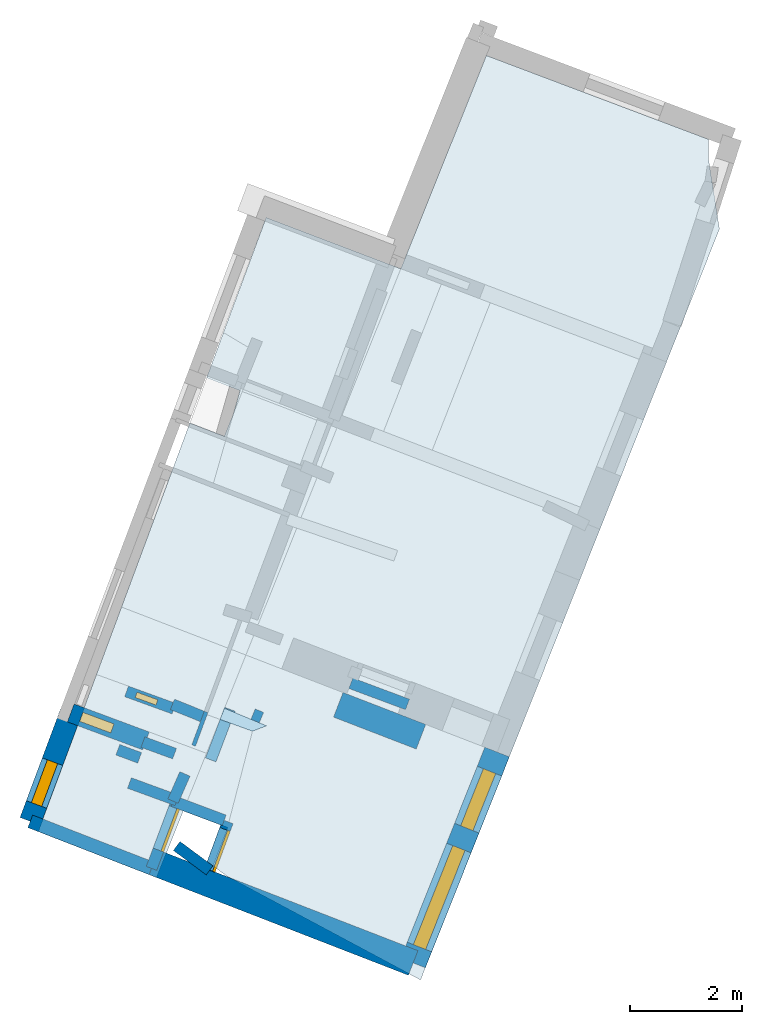
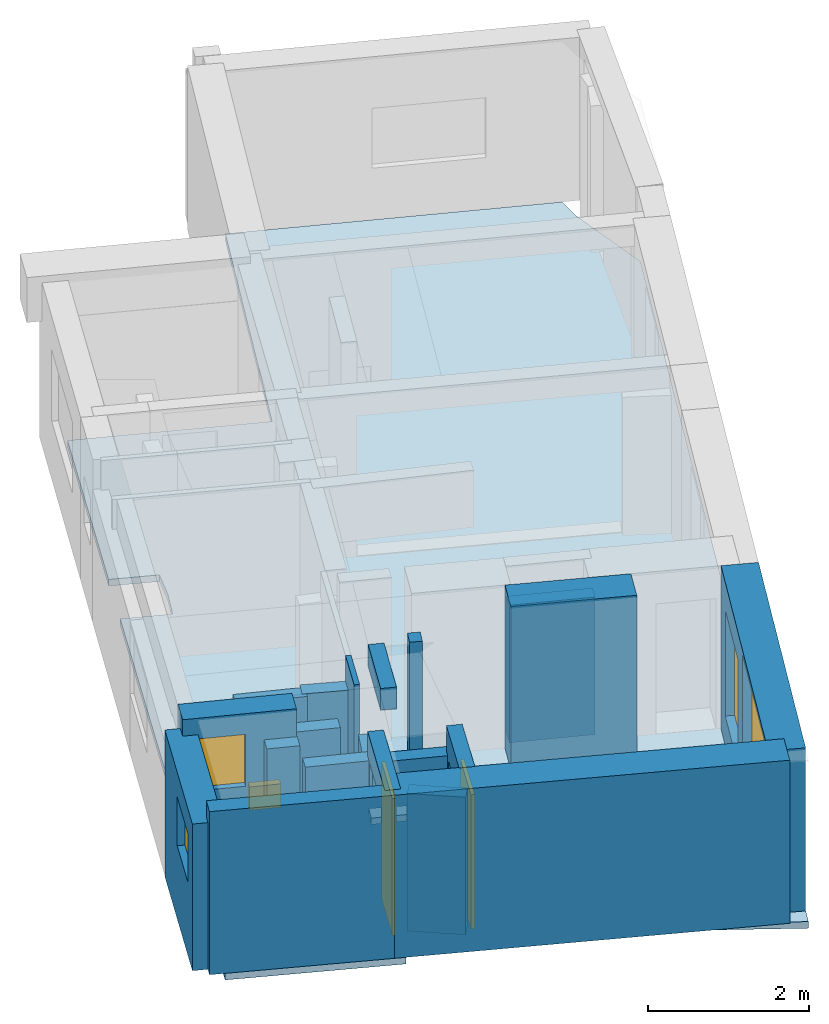
# One storey, part 1 of 5: 20 walls, 5 windows, 2 doors, 2 slabs, 7 openings.
"""IFC2X3 building model written with IfcOpenShell, lengths in metres."""

from ifc_helpers import new_model, entity, si_unit, converted_unit, derived_unit, direction, frame, frame_2d, origin, origin_2d_with_axis, place, context, subcontext, project, spatial, polyline, rectangle, outline, extrude, source, transform, mapped, material, layer, layer_set, layer_usage, type_object, type_shapes, element, fill, save


model = new_model("IFC2X3")

# Units and contexts
model_context = context("Model", 3, precision=1e-05, world=origin(), true_north=direction((0.0, 1.0)))
body_context = subcontext(model_context, "Body", "Model", "MODEL_VIEW")
ifc_project = project(units=[si_unit("LENGTHUNIT", "METRE"), si_unit("AREAUNIT", "SQUARE_METRE"), si_unit("VOLUMEUNIT", "CUBIC_METRE"), converted_unit("PLANEANGLEUNIT", "DEGREE", entity("IfcRatioMeasure", 0.0174532925199433), si_unit("PLANEANGLEUNIT", "RADIAN"), dimensions=[0, 0, 0, 0, 0, 0, 0]), si_unit("MASSUNIT", "GRAM", prefix="KILO"), derived_unit("MASSDENSITYUNIT", [(si_unit("MASSUNIT", "GRAM", prefix="KILO"), 1), (si_unit("LENGTHUNIT", "METRE"), -3)]), derived_unit("MOMENTOFINERTIAUNIT", [(si_unit("LENGTHUNIT", "METRE"), 4)]), si_unit("TIMEUNIT", "SECOND"), si_unit("FREQUENCYUNIT", "HERTZ"), si_unit("THERMODYNAMICTEMPERATUREUNIT", "DEGREE_CELSIUS"), derived_unit("THERMALTRANSMITTANCEUNIT", [(si_unit("MASSUNIT", "GRAM", prefix="KILO"), 1), (si_unit("THERMODYNAMICTEMPERATUREUNIT", "KELVIN"), -1), (si_unit("TIMEUNIT", "SECOND"), -3)]), derived_unit("VOLUMETRICFLOWRATEUNIT", [(si_unit("LENGTHUNIT", "METRE"), 3), (si_unit("TIMEUNIT", "SECOND"), -1)]), si_unit("ELECTRICCURRENTUNIT", "AMPERE"), si_unit("ELECTRICVOLTAGEUNIT", "VOLT"), si_unit("POWERUNIT", "WATT"), si_unit("FORCEUNIT", "NEWTON", prefix="KILO"), si_unit("ILLUMINANCEUNIT", "LUX"), si_unit("LUMINOUSFLUXUNIT", "LUMEN"), si_unit("LUMINOUSINTENSITYUNIT", "CANDELA"), derived_unit("USERDEFINED", [(si_unit("MASSUNIT", "GRAM", prefix="KILO"), -1), (si_unit("LENGTHUNIT", "METRE"), -2), (si_unit("TIMEUNIT", "SECOND"), 3), (si_unit("LUMINOUSFLUXUNIT", "LUMEN"), 1)]), derived_unit("LINEARVELOCITYUNIT", [(si_unit("LENGTHUNIT", "METRE"), 1), (si_unit("TIMEUNIT", "SECOND"), -1)]), si_unit("PRESSUREUNIT", "PASCAL"), derived_unit("USERDEFINED", [(si_unit("LENGTHUNIT", "METRE"), -2), (si_unit("MASSUNIT", "GRAM", prefix="KILO"), 1), (si_unit("TIMEUNIT", "SECOND"), -2)]), derived_unit("LINEARFORCEUNIT", [(si_unit("MASSUNIT", "GRAM", prefix="KILO"), 1), (si_unit("LENGTHUNIT", "METRE"), 1), (si_unit("TIMEUNIT", "SECOND"), -2), (si_unit("LENGTHUNIT", "METRE"), -1)]), derived_unit("PLANARFORCEUNIT", [(si_unit("MASSUNIT", "GRAM", prefix="KILO"), 1), (si_unit("LENGTHUNIT", "METRE"), 1), (si_unit("TIMEUNIT", "SECOND"), -2), (si_unit("LENGTHUNIT", "METRE"), -2)])], contexts=[model_context])

# Site, building, storey
placement_1 = place(None, origin())
site = spatial("IfcSite", under=ifc_project, at=placement_1, CompositionType="ELEMENT")
building = spatial("IfcBuilding", under=site, at=placement_1, CompositionType="ELEMENT")
storey_placement = place(placement_1, frame((0.0, 0.0, -81.7791442871094)))
storey = spatial("IfcBuildingStorey", under=building, at=storey_placement, Name="Level 1", CompositionType="ELEMENT", Elevation=-81.7791442871094)

# Slabs
ifc_material_1 = material(Name="Floor default")
ifc_layer_1 = layer(ifc_material_1, 0.1)
ifc_layer_set_1 = layer_set([ifc_layer_1], Name="Floor : 100mm")
ifc_layer_usage_1 = layer_usage(ifc_layer_set_1, "AXIS3", "POSITIVE", 0.0)
slab_type_1 = type_object("IfcSlabType", Name="Floor : 100mm", PredefinedType="FLOOR")
slab_1_placement = place(storey_placement, origin())
element("IfcSlab", 1, at=slab_1_placement, inside=storey, type_object=slab_type_1, material=ifc_layer_usage_1, Name="Floor : 100mm", ObjectType="Floor : 100mm", PredefinedType="FLOOR", context=body_context, shape_type="SweptSolid", body=[
    extrude(outline(polyline([(-3.49388003349304, 1.42888998985291), (-4.0716700553894, 1.63903999328613), (-3.99167990684509, 1.83849000930786), (-3.24238991737366, 1.52546000480652), (-3.49388003349304, 1.42888998985291)])), frame((0.0, 0.0, -0.1), z_axis=(0.0, 0.0, 1.0), x_axis=(1.0, 0.0, 0.0)), (0.0, 0.0, 1.0), 0.1),
])
ifc_layer_2 = layer(ifc_material_1, 0.1)
ifc_layer_set_2 = layer_set([ifc_layer_2], Name="Floor : 100mm")
ifc_layer_usage_2 = layer_usage(ifc_layer_set_2, "AXIS3", "POSITIVE", 0.0)
slab_type_2 = type_object("IfcSlabType", Name="Floor : 100mm", PredefinedType="FLOOR")
slab_2_placement = place(storey_placement, origin())
element("IfcSlab", 2, at=slab_2_placement, inside=storey, type_object=slab_type_2, material=ifc_layer_usage_2, Name="Floor : 100mm", ObjectType="Floor : 100mm", PredefinedType="FLOOR", context=body_context, shape_type="SweptSolid", body=[
    extrude(outline(polyline([(-0.497680008411407, -3.00534009933472), (1.08619999885559, 0.973829984664917), (2.70121002197266, 5.03125), (3.83908009529114, 7.88992023468018), (4.83017015457153, 10.3798503875732), (4.63234996795654, 11.6451902389526), (4.63234996795654, 11.9805402755737), (0.67492002248764, 13.4735298156738), (-0.849510014057159, 9.67273044586182), (-3.2506799697876, 10.5857696533203), (-4.01208019256592, 8.53514003753662), (-4.31142997741699, 7.72891998291016), (-3.71643996238708, 7.50004005432129), (-3.83523011207581, 7.08568000793457), (-3.99607992172241, 6.68628978729248), (-4.61093997955322, 6.92226982116699), (-4.93342018127441, 6.05374002456665), (-5.82860994338989, 3.64277005195618), (-6.27504014968872, 2.44042992591858), (-6.49514007568359, 1.84764003753662), (-7.31494998931885, -0.360320001840591), (-5.2023401260376, -1.17999005317688), (-4.90777015686035, -0.44556999206543), (-4.7262601852417, 0.00698000006377697), (-3.94035005569458, -0.28753998875618), (-4.20233011245728, -0.968050003051758), (-3.93070006370544, -1.16923999786377), (-0.497680008411407, -3.00534009933472)])), frame((0.0, 0.0, -0.1), z_axis=(0.0, 0.0, 1.0), x_axis=(1.0, 0.0, 0.0)), (0.0, 0.0, 1.0), 0.1),
])

# Walls
ifc_material_2 = material(Name="Default wall")
ifc_layer_3 = layer(ifc_material_2, 0.2)
ifc_layer_set_3 = layer_set([ifc_layer_3], Name="wall_thickness_0.2000")
ifc_layer_usage_3 = layer_usage(ifc_layer_set_3, "AXIS2", "POSITIVE", -0.1)
wall_type_1 = type_object("IfcWallType", Name="wall_thickness_0.2000", PredefinedType="STANDARD", material=ifc_layer_set_3)
wall_1_placement = place(storey_placement, frame((-4.69764743649111, 0.668284849217164, 0.0), z_axis=(0.0, 0.0, 1.0), x_axis=(-0.401525160425037, -0.915847992597924, 0.0)))
element("IfcWallStandardCase", 3, at=wall_1_placement, inside=storey, type_object=wall_type_1, material=ifc_layer_usage_3, Name="Wall:9", ObjectType="Wall", context=body_context, shape_type="SweptSolid", body=[
    extrude(outline(polyline([(0.530077874070879, -0.1), (0.530077874070879, 0.1), (0.0, 0.1), (0.0, -0.1), (0.530077874070879, -0.1)])), origin(), (0.0, 0.0, 1.0), 2.08080291748047),
])
wall_2_placement = place(storey_placement, frame((-4.84477685605442, -0.616664605192103, 0.0), z_axis=(0.0, 0.0, 1.0), x_axis=(0.803591772922501, -0.595180865360499, 0.0)))
element("IfcWallStandardCase", 4, at=wall_2_placement, inside=storey, type_object=wall_type_1, material=ifc_layer_usage_3, Name="Wall:11", ObjectType="Wall", context=body_context, shape_type="SweptSolid", body=[
    extrude(outline(polyline([(0.729999710162035, -0.1), (0.729999710162035, 0.1), (0.0, 0.1), (0.0, -0.1), (0.729999710162035, -0.1)])), origin(), (0.0, 0.0, 1.0), 2.08080291748047),
])
wall_3_placement = place(storey_placement, frame((-5.68688132326046, 0.505307002474708, 0.0), z_axis=(0.0, 0.0, 1.0), x_axis=(0.939382169316775, -0.34287190023347, 0.0)))
element("IfcWallStandardCase", 5, at=wall_3_placement, inside=storey, type_object=wall_type_1, material=ifc_layer_usage_3, Name="Wall:34", ObjectType="Wall", context=body_context, shape_type="SweptSolid", body=[
    extrude(outline(polyline([(0.902038816711558, -0.1), (0.902038816711558, 0.1), (0.0, 0.1), (0.0, -0.1), (0.902038816711558, -0.1)])), origin(), (0.0, 0.0, 1.0), 2.09180450439453),
])
wall_4_placement = place(storey_placement, frame((-5.50497072982383, 0.953843812868215, 0.0), z_axis=(0.0, 0.0, 1.0), x_axis=(-0.936839946646351, 0.34975836568646, 0.0)))
element("IfcWallStandardCase", 6, at=wall_4_placement, inside=storey, type_object=wall_type_1, material=ifc_layer_usage_3, Name="Wall:36", ObjectType="Wall", context=body_context, shape_type="SweptSolid", body=[
    extrude(outline(polyline([(0.415000130487096, -0.1), (0.415000130487096, 0.1), (0.0, 0.1), (0.0, -0.1), (0.415000130487096, -0.1)])), origin(), (0.0, 0.0, 1.0), 2.08080291748047),
])
wall_5_placement = place(storey_placement, frame((-4.91048679587615, 0.18281424211578, 0.0), z_axis=(0.0, 0.0, 1.0), x_axis=(0.936404472151035, -0.35092259051754, 0.0)))
element("IfcWallStandardCase", 7, at=wall_5_placement, inside=storey, type_object=wall_type_1, material=ifc_layer_usage_3, Name="Wall:40", ObjectType="Wall", context=body_context, shape_type="SweptSolid", body=[
    extrude(outline(polyline([(0.974388960445518, -0.1), (0.974388960445518, 0.1), (0.0, 0.1), (0.0, -0.1), (0.974388960445518, -0.1)])), origin(), (0.0, 0.0, 1.0), 2.08080291748047),
])

# Wall, opening, window
wall_6_placement = place(storey_placement, frame((-5.73748285038523, 2.13850509301801, 0.0), z_axis=(0.0, 0.0, 1.0), x_axis=(0.939770987295622, -0.341804756311861, 0.0)))
wall_6 = element("IfcWallStandardCase", 8, at=wall_6_placement, inside=storey, type_object=wall_type_1, material=ifc_layer_usage_3, Name="Wall:45", ObjectType="Wall", context=body_context, shape_type="SweptSolid", body=[
    extrude(outline(polyline([(0.899999824950968, -0.1), (0.899999824950968, 0.1), (0.0, 0.1), (0.0, -0.1), (0.899999824950968, -0.1)])), origin(), (0.0, 0.0, 1.0), 2.08080291748047),
])
opening_1_placement = place(wall_6_placement, frame((0.179999695044436, -0.1, 0.408058166503906)))
opening_1 = element("IfcOpeningElement", 9, at=opening_1_placement, cuts=wall_6, Name="Opening : 395 x 355 : 11", ObjectType="Opening", context=body_context, shape_type="SweptSolid", body=[
    extrude(rectangle(XDim=0.395, YDim=0.355, at=frame_2d((0.1775, 0.1975), x_axis=(0.0, 1.0))), frame((0.0, 0.0, 0.0), z_axis=(0.0, 1.0, 0.0), x_axis=(0.0, 0.0, 1.0)), (0.0, 0.0, 1.0), 0.2),
])
ifc_material_3 = material(Name="Window Default")
window_style_1 = type_object("IfcWindowStyle", Name="Window : 395 x 355mm", ConstructionType="NOTDEFINED", OperationType="NOTDEFINED", ParameterTakesPrecedence=False, Sizeable=False, material=ifc_material_3)
shared_shape_1 = source(origin(), body_context, "Body", "SweptSolid", [
    extrude(rectangle(XDim=0.1, YDim=0.395, at=origin_2d_with_axis()), frame((0.1975, 0.1, 0.0), z_axis=(0.0, 0.0, 1.0), x_axis=(0.0, 1.0, 0.0)), (0.0, 0.0, 1.0), 0.355),
])
type_shapes(window_style_1, [shared_shape_1])
window_1_placement = place(opening_1_placement, origin())
window_1 = element("IfcWindow", 10, at=window_1_placement, inside=storey, type_object=window_style_1, Name="Window : 395 x 355mm : 9", ObjectType="Window : 395 x 355mm", OverallHeight=0.355, OverallWidth=0.395, context=body_context, shape_type="MappedRepresentation", body=[
    mapped(shared_shape_1, transform((0.0, 0.0, 0.0), scale=1.0)),
])
fill(opening_1, window_1)

# Wall, opening, door
wall_7_placement = place(storey_placement, frame((-4.83952210720287, 0.196022988020994, 0.0), z_axis=(0.0, 0.0, 1.0), x_axis=(-0.351109422703941, -0.93633443453101, 0.0)))
wall_7 = element("IfcWallStandardCase", 11, at=wall_7_placement, inside=storey, type_object=wall_type_1, material=ifc_layer_usage_3, Name="Wall:61", ObjectType="Wall", context=body_context, shape_type="SweptSolid", body=[
    extrude(outline(polyline([(1.29416324547579, -0.1), (1.29416324547579, 0.1), (0.0, 0.1), (0.0, -0.1), (1.29416324547579, -0.1)])), origin(), (0.0, 0.0, 1.0), 2.46645965576172),
])
opening_2_placement = place(wall_7_placement, frame((0.135700394585531, -0.1, 0.0158004760742188)))
opening_2 = element("IfcOpeningElement", 12, at=opening_2_placement, cuts=wall_7, Name="Opening : 810 x 2070 : 16", ObjectType="Opening", context=body_context, shape_type="SweptSolid", body=[
    extrude(rectangle(XDim=0.81, YDim=2.07, at=frame_2d((1.035, 0.405), x_axis=(0.0, 1.0))), frame((0.0, 0.0, 0.0), z_axis=(0.0, 1.0, 0.0), x_axis=(0.0, 0.0, 1.0)), (0.0, 0.0, 1.0), 0.2),
])
ifc_material_4 = material(Name="Door Panel")
door_style_1 = type_object("IfcDoorStyle", Name="Door : 810 x 2070mm", ConstructionType="NOTDEFINED", OperationType="SINGLE_SWING_RIGHT", ParameterTakesPrecedence=False, Sizeable=False, material=ifc_material_4)
shared_shape_2 = source(origin(), body_context, "Body", "SweptSolid", [
    extrude(rectangle(XDim=0.05, YDim=0.81, at=origin_2d_with_axis()), frame((0.405, 0.175, 0.0), z_axis=(0.0, 0.0, 1.0), x_axis=(0.0, 1.0, 0.0)), (0.0, 0.0, 1.0), 2.07),
])
type_shapes(door_style_1, [shared_shape_2])
door_1_placement = place(opening_2_placement, origin())
door_1 = element("IfcDoor", 13, at=door_1_placement, inside=storey, type_object=door_style_1, Name="Door : 810 x 2070mm : 2", ObjectType="Door : 810 x 2070mm", OverallHeight=2.07, OverallWidth=0.81, context=body_context, shape_type="MappedRepresentation", body=[
    mapped(shared_shape_2, transform((0.0, 0.0, 0.0), scale=1.0)),
])
fill(opening_2, door_1)

wall_8_placement = place(storey_placement, frame((-3.93370529681326, -0.183239726440564, 0.0), z_axis=(0.0, 0.0, 1.0), x_axis=(-0.345762204330425, -0.938322171781401, 0.0)))
wall_8 = element("IfcWallStandardCase", 14, at=wall_8_placement, inside=storey, type_object=wall_type_1, material=ifc_layer_usage_3, Name="Wall:76", ObjectType="Wall", context=body_context, shape_type="SweptSolid", body=[
    extrude(outline(polyline([(0.927830297948159, -0.1), (0.927830297948159, 0.1), (0.0, 0.1), (0.0, -0.1), (0.927830297948159, -0.1)])), origin(), (0.0, 0.0, 1.0), 2.46645965576172),
])
opening_3_placement = place(wall_8_placement, frame((0.146446355377596, -0.1, 0.00879669189453125)))
opening_3 = element("IfcOpeningElement", 15, at=opening_3_placement, cuts=wall_8, Name="Opening : 775 x 2030 : 22", ObjectType="Opening", context=body_context, shape_type="SweptSolid", body=[
    extrude(rectangle(XDim=0.775, YDim=2.03, at=frame_2d((1.015, 0.3875), x_axis=(0.0, 1.0))), frame((0.0, 0.0, 0.0), z_axis=(0.0, 1.0, 0.0), x_axis=(0.0, 0.0, 1.0)), (0.0, 0.0, 1.0), 0.2),
])
door_style_2 = type_object("IfcDoorStyle", Name="Door : 775 x 2030mm", ConstructionType="NOTDEFINED", OperationType="SINGLE_SWING_RIGHT", ParameterTakesPrecedence=False, Sizeable=False, material=ifc_material_4)
shared_shape_3 = source(origin(), body_context, "Body", "SweptSolid", [
    extrude(rectangle(XDim=0.05, YDim=0.775, at=origin_2d_with_axis()), frame((0.3875, 0.175, 0.0), z_axis=(0.0, 0.0, 1.0), x_axis=(0.0, 1.0, 0.0)), (0.0, 0.0, 1.0), 2.03),
])
type_shapes(door_style_2, [shared_shape_3])
door_2_placement = place(opening_3_placement, origin())
door_2 = element("IfcDoor", 16, at=door_2_placement, inside=storey, type_object=door_style_2, Name="Door : 775 x 2030mm : 5", ObjectType="Door : 775 x 2030mm", OverallHeight=2.03, OverallWidth=0.775, context=body_context, shape_type="MappedRepresentation", body=[
    mapped(shared_shape_3, transform((0.0, 0.0, 0.0), scale=1.0)),
])
fill(opening_3, door_2)

# Walls
wall_9_placement = place(storey_placement, frame((-1.74015555347934, 2.28371564240451, 0.0), z_axis=(0.0, 0.0, 1.0), x_axis=(0.936778285254974, -0.349923483457099, 0.0)))
element("IfcWallStandardCase", 17, at=wall_9_placement, inside=storey, type_object=wall_type_1, material=ifc_layer_usage_3, Name="Wall:80", ObjectType="Wall", context=body_context, shape_type="SweptSolid", body=[
    extrude(outline(polyline([(1.07814449094911, -0.1), (1.07814449094911, 0.1), (0.0, 0.1), (0.0, -0.1), (1.07814449094911, -0.1)])), origin(), (0.0, 0.0, 1.0), 2.08080291748047),
])
wall_10_placement = place(storey_placement, frame((-4.92037903602146, 1.90727218548898, 0.0), z_axis=(0.0, 0.0, 1.0), x_axis=(0.927278241760795, -0.374372892123626, 0.0)))
element("IfcWallStandardCase", 18, at=wall_10_placement, inside=storey, type_object=wall_type_1, material=ifc_layer_usage_3, Name="Wall:86", ObjectType="Wall", context=body_context, shape_type="SweptSolid", body=[
    extrude(outline(polyline([(0.609526141531859, -0.1), (0.609526141531859, 0.1), (0.0, 0.1), (0.0, -0.1), (0.609526141531859, -0.1)])), origin(), (0.0, 0.0, 1.0), 2.08080291748047),
])
ifc_layer_4 = layer(ifc_material_2, 0.469999998807907)
ifc_layer_set_4 = layer_set([ifc_layer_4], Name="wall_thickness_0.4700")
ifc_layer_usage_4 = layer_usage(ifc_layer_set_4, "AXIS2", "POSITIVE", -0.234999999403954)
wall_type_2 = type_object("IfcWallType", Name="wall_thickness_0.4700", PredefinedType="STANDARD", material=ifc_layer_set_4)
wall_11_placement = place(storey_placement, frame((-1.96446391737697, 1.89940987600021, 0.0), z_axis=(0.0, 0.0, 1.0), x_axis=(0.932920275492901, -0.360082989842966, 0.0)))
element("IfcWallStandardCase", 19, at=wall_11_placement, inside=storey, type_object=wall_type_2, material=ifc_layer_usage_4, Name="Wall:14", ObjectType="Wall", context=body_context, shape_type="SweptSolid", body=[
    extrude(outline(polyline([(1.57982514113174, -0.234999999403954), (1.57982514113174, 0.234999999403954), (0.0, 0.234999999403954), (0.0, -0.234999999403954), (1.57982514113174, -0.234999999403954)])), origin(), (0.0, 0.0, 1.0), 2.46645965576172),
])

# Wall, openings, windows
wall_12_placement = place(storey_placement, frame((0.866960459031093, 1.05848709394959, 0.0), z_axis=(0.0, 0.0, 1.0), x_axis=(-0.369820361237659, -0.929103277582233, 0.0)))
wall_12 = element("IfcWallStandardCase", 20, at=wall_12_placement, inside=storey, type_object=wall_type_2, material=ifc_layer_usage_4, Name="Wall:24", ObjectType="Wall", context=body_context, shape_type="SweptSolid", body=[
    extrude(outline(polyline([(4.04742735328638, -0.234999999403954), (4.04742735328638, 0.234999999403954), (0.0, 0.234999999403954), (0.0, -0.234999999403954), (4.04742735328638, -0.234999999403954)])), origin(), (0.0, 0.0, 1.0), 2.46645965576172),
])
opening_4_placement = place(wall_12_placement, frame((1.84168409532844, -0.234999999403954, 0.450057983398438)))
opening_4 = element("IfcOpeningElement", 21, at=opening_4_placement, cuts=wall_12, Name="Opening : 1900 x 1950 : 7", ObjectType="Opening", context=body_context, shape_type="SweptSolid", body=[
    extrude(rectangle(XDim=1.9, YDim=1.95, at=frame_2d((0.975, 0.95), x_axis=(0.0, 1.0))), frame((0.0, 0.0, 0.0), z_axis=(0.0, 1.0, 0.0), x_axis=(0.0, 0.0, 1.0)), (0.0, 0.0, 1.0), 0.469999998807907),
])
opening_5_placement = place(wall_12_placement, frame((0.366683535874474, -0.234999999403954, 0.445060729980469)))
opening_5 = element("IfcOpeningElement", 22, at=opening_5_placement, cuts=wall_12, Name="Opening : 1095 x 1605 : 8", ObjectType="Opening", context=body_context, shape_type="SweptSolid", body=[
    extrude(rectangle(XDim=1.095, YDim=1.605, at=frame_2d((0.8025, 0.5475), x_axis=(0.0, 1.0))), frame((0.0, 0.0, 0.0), z_axis=(0.0, 1.0, 0.0), x_axis=(0.0, 0.0, 1.0)), (0.0, 0.0, 1.0), 0.469999998807907),
])
window_style_2 = type_object("IfcWindowStyle", Name="Window : 1900 x 1950mm", ConstructionType="NOTDEFINED", OperationType="NOTDEFINED", ParameterTakesPrecedence=False, Sizeable=False, material=ifc_material_3)
shared_shape_4 = source(origin(), body_context, "Body", "SweptSolid", [
    extrude(rectangle(XDim=0.234999999403954, YDim=1.9, at=origin_2d_with_axis()), frame((0.95, 0.234999999403954, 0.0), z_axis=(0.0, 0.0, 1.0), x_axis=(0.0, 1.0, 0.0)), (0.0, 0.0, 1.0), 1.95),
])
type_shapes(window_style_2, [shared_shape_4])
window_2_placement = place(opening_4_placement, origin())
window_2 = element("IfcWindow", 23, at=window_2_placement, inside=storey, type_object=window_style_2, Name="Window : 1900 x 1950mm : 6", ObjectType="Window : 1900 x 1950mm", OverallHeight=1.95, OverallWidth=1.9, context=body_context, shape_type="MappedRepresentation", body=[
    mapped(shared_shape_4, transform((0.0, 0.0, 0.0), scale=1.0)),
])
fill(opening_4, window_2)
window_style_3 = type_object("IfcWindowStyle", Name="Window : 1095 x 1605mm", ConstructionType="NOTDEFINED", OperationType="NOTDEFINED", ParameterTakesPrecedence=False, Sizeable=False, material=ifc_material_3)
shared_shape_5 = source(origin(), body_context, "Body", "SweptSolid", [
    extrude(rectangle(XDim=0.234999999403954, YDim=1.095, at=origin_2d_with_axis()), frame((0.5475, 0.234999999403954, 0.0), z_axis=(0.0, 0.0, 1.0), x_axis=(0.0, 1.0, 0.0)), (0.0, 0.0, 1.0), 1.605),
])
type_shapes(window_style_3, [shared_shape_5])
window_3_placement = place(opening_5_placement, origin())
window_3 = element("IfcWindow", 24, at=window_3_placement, inside=storey, type_object=window_style_3, Name="Window : 1095 x 1605mm : 7", ObjectType="Window : 1095 x 1605mm", OverallHeight=1.605, OverallWidth=1.095, context=body_context, shape_type="MappedRepresentation", body=[
    mapped(shared_shape_5, transform((0.0, 0.0, 0.0), scale=1.0)),
])
fill(opening_5, window_3)

# Walls
wall_13_placement = place(storey_placement, frame((-5.25353390987708, -0.90806136548735, 0.0), z_axis=(0.0, 0.0, 1.0), x_axis=(0.932288239813178, -0.361716239483448, 0.0)))
element("IfcWallStandardCase", 25, at=wall_13_placement, inside=storey, type_object=wall_type_2, material=ifc_layer_usage_4, Name="Wall:79", ObjectType="Wall", context=body_context, shape_type="SweptSolid", body=[
    extrude(outline(polyline([(4.95949020404541, -0.234999999403954), (4.95949020404541, 0.234999999403954), (0.0, 0.234999999403954), (0.0, -0.234999999403954), (4.95949020404541, -0.234999999403954)])), origin(), (0.0, 0.0, 1.0), 2.46645965576172),
])
ifc_layer_5 = layer(ifc_material_2, 0.200000002980232)
ifc_layer_set_5 = layer_set([ifc_layer_5], Name="wall_thickness_0.2000")
ifc_layer_usage_5 = layer_usage(ifc_layer_set_5, "AXIS2", "POSITIVE", -0.100000001490116)
wall_type_3 = type_object("IfcWallType", Name="wall_thickness_0.2000", PredefinedType="STANDARD", material=ifc_layer_set_5)
wall_14_placement = place(storey_placement, frame((-5.44601596829698, 1.23545246294027, 0.0), z_axis=(0.0, 0.0, 1.0), x_axis=(0.938989410487738, -0.343946052444117, 0.0)))
element("IfcWallStandardCase", 26, at=wall_14_placement, inside=storey, type_object=wall_type_3, material=ifc_layer_usage_5, Name="Wall:37", ObjectType="Wall", context=body_context, shape_type="SweptSolid", body=[
    extrude(outline(polyline([(0.5999999430684, -0.100000001490116), (0.5999999430684, 0.100000001490116), (0.0, 0.100000001490116), (0.0, -0.100000001490116), (0.5999999430684, -0.100000001490116)])), origin(), (0.0, 0.0, 1.0), 2.09180450439453),
])
wall_15_placement = place(storey_placement, frame((-3.48307672977927, 1.73438207648659, 0.0), z_axis=(0.0, 0.0, 1.0), x_axis=(0.922714752018129, -0.385483445050656, 0.0)))
element("IfcWallStandardCase", 27, at=wall_15_placement, inside=storey, type_object=wall_type_3, material=ifc_layer_usage_5, Name="Wall:67", ObjectType="Wall", context=body_context, shape_type="SweptSolid", body=[
    extrude(outline(polyline([(0.162148914171099, -0.100000001490116), (0.162148914171099, 0.100000001490116), (0.0, 0.100000001490116), (0.0, -0.100000001490116), (0.162148914171099, -0.100000001490116)])), origin(), (0.0, 0.0, 1.0), 2.46645965576172),
])
placement_2 = place(placement_1, frame((0.0, 0.0, -79.6408615112305)))
wall_16_placement = place(placement_2, frame((-3.895834072577, 1.81995790383597, 0.0), z_axis=(0.0, 0.0, 1.0), x_axis=(-0.354427791740161, -0.935083386892417, 0.0)))
element("IfcWallStandardCase", 28, at=wall_16_placement, inside=storey, type_object=wall_type_3, material=ifc_layer_usage_5, Name="Wall:71", ObjectType="Wall", context=body_context, shape_type="SweptSolid", body=[
    extrude(outline(polyline([(0.965000216641399, -0.100000001490116), (0.965000216641399, 0.100000001490116), (0.0, 0.100000001490116), (0.0, -0.100000001490116), (0.965000216641399, -0.100000001490116)])), origin(), (0.0, 0.0, 1.0), 0.328176879882818),
])

# Wall, opening, window
ifc_layer_6 = layer(ifc_material_2, 0.389999985694885)
ifc_layer_set_6 = layer_set([ifc_layer_6], Name="wall_thickness_0.3900")
ifc_layer_usage_6 = layer_usage(ifc_layer_set_6, "AXIS2", "POSITIVE", -0.194999992847443)
wall_type_4 = type_object("IfcWallType", Name="wall_thickness_0.3900", PredefinedType="STANDARD", material=ifc_layer_set_6)
wall_17_placement = place(storey_placement, frame((-6.73337083681349, 1.75489114429114, 0.0), z_axis=(0.0, 0.0, 1.0), x_axis=(-0.349788325778086, -0.936828760846593, 0.0)))
wall_17 = element("IfcWallStandardCase", 29, at=wall_17_placement, inside=storey, type_object=wall_type_4, material=ifc_layer_usage_6, Name="Wall:18", ObjectType="Wall", context=body_context, shape_type="SweptSolid", body=[
    extrude(outline(polyline([(2.06252722424709, -0.194999992847443), (2.06252722424709, 0.194999992847443), (0.0, 0.194999992847443), (0.0, -0.194999992847443), (2.06252722424709, -0.194999992847443)])), origin(), (0.0, 0.0, 1.0), 2.21805572509766),
])
opening_6_placement = place(wall_17_placement, frame((0.927276761517667, -0.194999992847443, 1.10706329345703)))
opening_6 = element("IfcOpeningElement", 30, at=opening_6_placement, cuts=wall_17, Name="Opening : 815 x 735 : 4", ObjectType="Opening", context=body_context, shape_type="SweptSolid", body=[
    extrude(rectangle(XDim=0.815, YDim=0.735, at=frame_2d((0.3675, 0.4075), x_axis=(0.0, 1.0))), frame((0.0, 0.0, 0.0), z_axis=(0.0, 1.0, 0.0), x_axis=(0.0, 0.0, 1.0)), (0.0, 0.0, 1.0), 0.389999985694885),
])
window_style_4 = type_object("IfcWindowStyle", Name="Window : 815 x 735mm", ConstructionType="NOTDEFINED", OperationType="NOTDEFINED", ParameterTakesPrecedence=False, Sizeable=False, material=ifc_material_3)
shared_shape_6 = source(origin(), body_context, "Body", "SweptSolid", [
    extrude(rectangle(XDim=0.194999992847443, YDim=0.815, at=origin_2d_with_axis()), frame((0.4075, 0.194999992847443, 0.0), z_axis=(0.0, 0.0, 1.0), x_axis=(0.0, 1.0, 0.0)), (0.0, 0.0, 1.0), 0.735),
])
type_shapes(window_style_4, [shared_shape_6])
window_4_placement = place(opening_6_placement, origin())
window_4 = element("IfcWindow", 31, at=window_4_placement, inside=storey, type_object=window_style_4, Name="Window : 815 x 735mm : 3", ObjectType="Window : 815 x 735mm", OverallHeight=0.735, OverallWidth=0.815, context=body_context, shape_type="MappedRepresentation", body=[
    mapped(shared_shape_6, transform((0.0, 0.0, 0.0), scale=1.0)),
])
fill(opening_6, window_4)

# Walls
ifc_layer_7 = layer(ifc_material_2, 0.239999994635582)
ifc_layer_set_7 = layer_set([ifc_layer_7], Name="wall_thickness_0.2400")
ifc_layer_usage_7 = layer_usage(ifc_layer_set_7, "AXIS2", "POSITIVE", -0.119999997317791)
wall_type_5 = type_object("IfcWallType", Name="wall_thickness_0.2400", PredefinedType="STANDARD", material=ifc_layer_set_7)
wall_18_placement = place(storey_placement, frame((-7.45481832185231, -0.177343209280572, 0.0), z_axis=(0.0, 0.0, 1.0), x_axis=(0.932288238779399, -0.361716242147911, 0.0)))
element("IfcWallStandardCase", 32, at=wall_18_placement, inside=storey, type_object=wall_type_5, material=ifc_layer_usage_7, Name="Wall:78", ObjectType="Wall", context=body_context, shape_type="SweptSolid", body=[
    extrude(outline(polyline([(2.31784961000176, -0.119999997317791), (2.31784961000176, 0.119999997317791), (0.0, 0.119999997317791), (0.0, -0.119999997317791), (2.31784961000176, -0.119999997317791)])), origin(), (0.0, 0.0, 1.0), 2.46645965576172),
])
ifc_layer_8 = layer(ifc_material_2, 0.0700000002980232)
ifc_layer_set_8 = layer_set([ifc_layer_8], Name="wall_thickness_0.0700")
ifc_layer_usage_8 = layer_usage(ifc_layer_set_8, "AXIS2", "POSITIVE", -0.0350000001490116)
wall_type_6 = type_object("IfcWallType", Name="wall_thickness_0.0700", PredefinedType="STANDARD", material=ifc_layer_set_8)
wall_19_placement = place(storey_placement, frame((-4.32039495416104, 1.77279491945072, 0.0), z_axis=(0.0, 0.0, 1.0), x_axis=(-0.347980739996071, -0.937501682447443, 0.0)))
element("IfcWallStandardCase", 33, at=wall_19_placement, inside=storey, type_object=wall_type_6, material=ifc_layer_usage_8, Name="Wall:75", ObjectType="Wall", context=body_context, shape_type="SweptSolid", body=[
    extrude(outline(polyline([(0.638912198738306, -0.0350000001490116), (0.638912198738306, 0.0350000001490116), (0.0, 0.0350000001490116), (0.0, -0.0350000001490116), (0.638912198738306, -0.0350000001490116)])), origin(), (0.0, 0.0, 1.0), 2.46645965576172),
])

# Wall, opening, window
ifc_layer_9 = layer(ifc_material_2, 0.340000003576279)
ifc_layer_set_9 = layer_set([ifc_layer_9], Name="wall_thickness_0.3400")
ifc_layer_usage_9 = layer_usage(ifc_layer_set_9, "AXIS2", "POSITIVE", -0.170000001788139)
wall_type_7 = type_object("IfcWallType", Name="wall_thickness_0.3400", PredefinedType="STANDARD", material=ifc_layer_set_9)
placement_3 = place(placement_1, frame((0.0, 0.0, -80.9336013793945)))
wall_20_placement = place(placement_3, frame((-6.73337126772923, 1.75489130368034, 0.0), z_axis=(0.0, 0.0, 1.0), x_axis=(0.937230193434629, -0.348711291062516, 0.0)))
wall_20 = element("IfcWallStandardCase", 34, at=wall_20_placement, inside=storey, type_object=wall_type_7, material=ifc_layer_usage_9, Name="Wall:59", ObjectType="Wall", context=body_context, shape_type="SweptSolid", body=[
    extrude(outline(polyline([(1.43051677586655, -0.170000001788139), (1.43051677586655, 0.170000001788139), (0.0, 0.170000001788139), (0.0, -0.170000001788139), (1.43051677586655, -0.170000001788139)])), origin(), (0.0, 0.0, 1.0), 1.62091674804688),
])
opening_7_placement = place(wall_20_placement, frame((0.202063091348191, -0.170000001788139, 0.523002624511719)))
opening_7 = element("IfcOpeningElement", 35, at=opening_7_placement, cuts=wall_20, Name="Opening : 590 x 785 : 15", ObjectType="Opening", context=body_context, shape_type="SweptSolid", body=[
    extrude(rectangle(XDim=0.59, YDim=0.785, at=frame_2d((0.3925, 0.295), x_axis=(0.0, 1.0))), frame((0.0, 0.0, 0.0), z_axis=(0.0, 1.0, 0.0), x_axis=(0.0, 0.0, 1.0)), (0.0, 0.0, 1.0), 0.340000003576279),
])
window_style_5 = type_object("IfcWindowStyle", Name="Window : 590 x 785mm", ConstructionType="NOTDEFINED", OperationType="NOTDEFINED", ParameterTakesPrecedence=False, Sizeable=False, material=ifc_material_3)
shared_shape_7 = source(origin(), body_context, "Body", "SweptSolid", [
    extrude(rectangle(XDim=0.170000001788139, YDim=0.59, at=origin_2d_with_axis()), frame((0.295, 0.170000001788139, 0.0), z_axis=(0.0, 0.0, 1.0), x_axis=(0.0, 1.0, 0.0)), (0.0, 0.0, 1.0), 0.785),
])
type_shapes(window_style_5, [shared_shape_7])
window_5_placement = place(opening_7_placement, origin())
window_5 = element("IfcWindow", 36, at=window_5_placement, inside=storey, type_object=window_style_5, Name="Window : 590 x 785mm : 12", ObjectType="Window : 590 x 785mm", OverallHeight=0.785, OverallWidth=0.59, context=body_context, shape_type="MappedRepresentation", body=[
    mapped(shared_shape_7, transform((0.0, 0.0, 0.0), scale=1.0)),
])
fill(opening_7, window_5)

save(model, "model.ifc")
